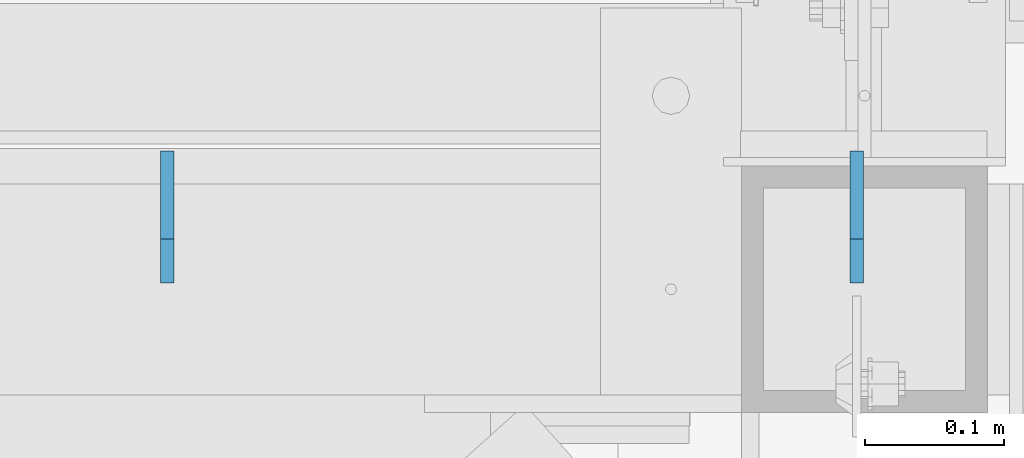
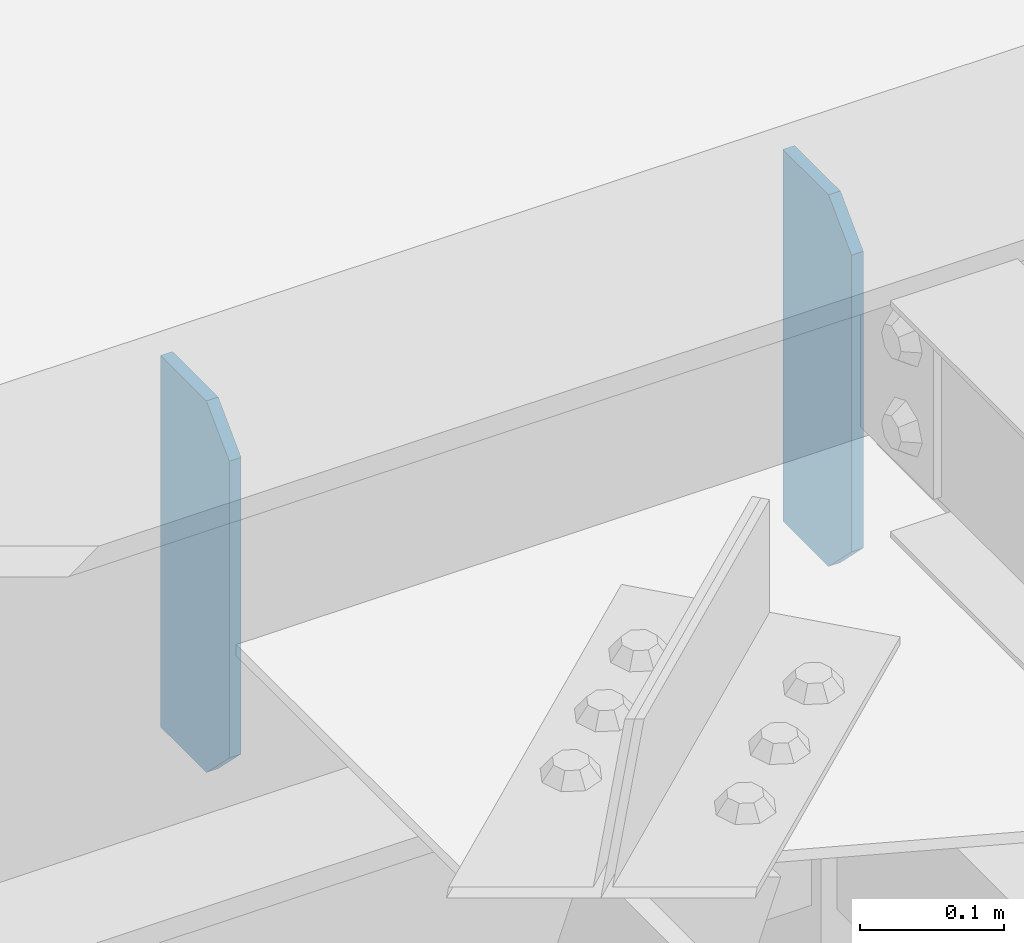
# One storey, part 1450 of 1763: 2 plates, 1 element without a shape of its own.
"""IFC2X3 building model written with IfcOpenShell, lengths in millimetres."""

from ifc_helpers import new_model, si_unit, frame, origin_with_axes, place, context, subcontext, project, spatial, faceted_brep, material, type_object, element, aggregate, save


model = new_model("IFC2X3")

# Units and contexts
model_context = context("Model", 3, precision=1e-05, world=origin_with_axes())
body_context = subcontext(model_context, "Body", "Model", "MODEL_VIEW")
ifc_project = project(units=[si_unit("LENGTHUNIT", "METRE", prefix="MILLI"), si_unit("AREAUNIT", "SQUARE_METRE"), si_unit("VOLUMEUNIT", "CUBIC_METRE"), si_unit("MASSUNIT", "GRAM", prefix="KILO"), si_unit("TIMEUNIT", "SECOND"), si_unit("PLANEANGLEUNIT", "RADIAN"), si_unit("SOLIDANGLEUNIT", "STERADIAN"), si_unit("THERMODYNAMICTEMPERATUREUNIT", "DEGREE_CELSIUS"), si_unit("LUMINOUSINTENSITYUNIT", "LUMEN")], contexts=[model_context])

# Site, building, storey
site_placement = place(None, origin_with_axes())
site = spatial("IfcSite", under=ifc_project, at=site_placement, CompositionType="ELEMENT")
building_placement = place(site_placement, origin_with_axes())
building = spatial("IfcBuilding", under=site, at=building_placement, Name="Undefined", CompositionType="ELEMENT")
storey_placement = place(building_placement, origin_with_axes())
storey = spatial("IfcBuildingStorey", under=building, at=storey_placement, Name="Undefined", CompositionType="ELEMENT", Elevation=0.0)

# Assembly, plates
assembly_placement = place(storey_placement, origin_with_axes())
assembly = element("IfcElementAssembly", 1, at=assembly_placement, inside=storey, Name="BEAM", AssemblyPlace="NOTDEFINED", PredefinedType="RIGID_FRAME")
ifc_material = material(Name="STEEL/A36")
plate_type = type_object("IfcPlateType", PredefinedType="NOTDEFINED")
plate_1_placement = place(assembly_placement, frame((-63216.0588430515, -14574.8397159135, 18488.025), z_axis=(0.0, 0.0, 1.0), x_axis=(0.0, 1.0, 0.0)))
plate_1 = element("IfcPlate", 2, at=plate_1_placement, type_object=plate_type, material=ifc_material, Name="PLATE", context=body_context, shape_type="Brep", body=[
    faceted_brep([(0.0, -4.76250000000073, 31.75), (-3.63797880709171e-12, -4.76249999999709, 282.575012207031), (3.63797880709171e-12, 4.76249999999709, 282.575012207031), (0.0, 4.76250000000073, 31.75), (31.7499999999964, -4.7625000000844, 314.325012207031), (31.7500000000036, 4.76249999991705, 314.325012207031), (95.2499999999964, -4.76250000025902, 314.325012207031), (95.2500000000036, 4.76249999974243, 314.325012207031), (95.2499999999964, -4.76250000025902, 0.0), (95.2500000000036, 4.76249999974243, 0.0), (31.75, -4.76250000000073, 0.0), (31.75, 4.76250000000073, 0.0)], [[[0, 1, 2, 3]], [[1, 4, 5, 2]], [[4, 6, 7, 5]], [[6, 8, 9, 7]], [[8, 10, 11, 9]], [[10, 0, 3, 11]], [[5, 7, 9, 11, 3, 2]], [[10, 8, 6, 4, 1, 0]]]),
])
plate_2_placement = place(assembly_placement, frame((-63713.74059237, -14574.8397129274, 18488.025), z_axis=(0.0, 0.0, 1.0), x_axis=(0.0, 1.0, 0.0)))
plate_2 = element("IfcPlate", 3, at=plate_2_placement, type_object=plate_type, material=ifc_material, Name="PLATE", context=body_context, shape_type="Brep", body=[
    faceted_brep([(0.0, -4.76250000000073, 31.75), (-3.63797880709171e-12, -4.76249999999709, 282.575012207031), (3.63797880709171e-12, 4.76249999999709, 282.575012207031), (0.0, 4.76250000000073, 31.75), (31.7499999999964, -4.7625000000844, 314.325012207031), (31.7500000000036, 4.76249999991705, 314.325012207031), (95.2499999999964, -4.76250000025902, 314.325012207031), (95.2500000000036, 4.76249999974243, 314.325012207031), (95.2499999999964, -4.76250000025902, 0.0), (95.2500000000036, 4.76249999974243, 0.0), (31.75, -4.76250000000073, 0.0), (31.75, 4.76250000000073, 0.0)], [[[0, 1, 2, 3]], [[1, 4, 5, 2]], [[4, 6, 7, 5]], [[6, 8, 9, 7]], [[8, 10, 11, 9]], [[10, 0, 3, 11]], [[5, 7, 9, 11, 3, 2]], [[10, 8, 6, 4, 1, 0]]]),
])
aggregate(assembly, [plate_1, plate_2])

save(model, "model.ifc")
